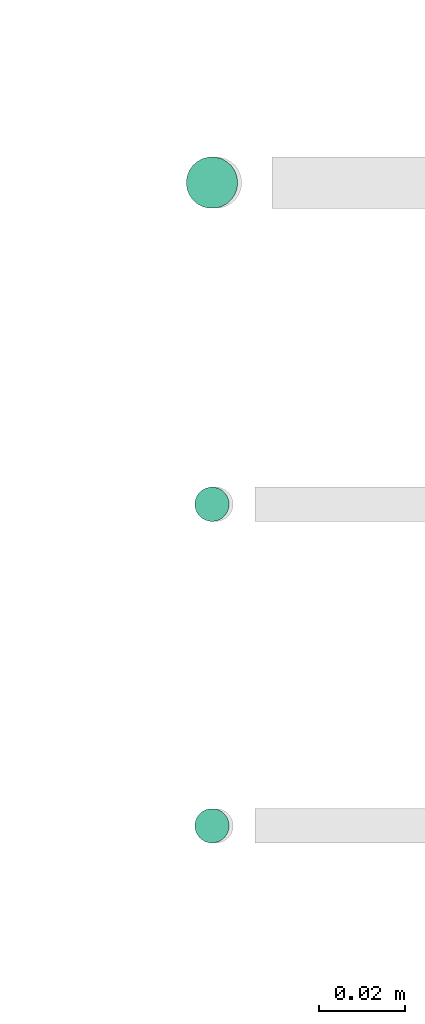
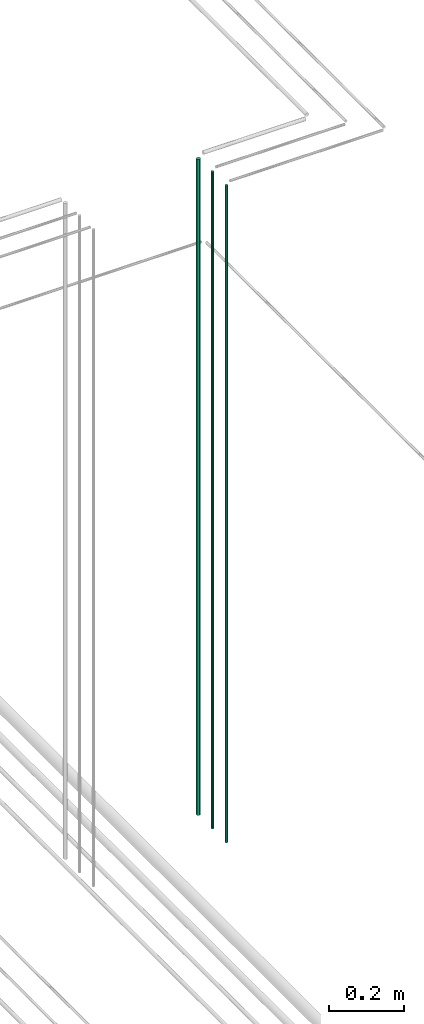
# One storey, part 46 of 331: 3 flow segments.
"""IFC2X3 building model written with IfcOpenShell, lengths in millimetres."""

import ifcopenshell
import ifcopenshell.guid

model = None  # the IFC model being written
_history = None  # IfcOwnerHistory: only IFC2X3 demands one
_inside = {}  # id of a spatial element -> (the spatial element, [elements in it])
_under = {}  # id of a project, library or spatial element -> (it, [spatial elements below it])
_declared = {}  # id of a project -> (the project, [libraries it declares])
_typed = {}  # id of a type object -> (the type object, [elements of that type])
_made_of = {}  # id of a material, layer set ... -> (it, [elements and type objects made of it])


def new_model(schema):
    """Start an empty IFC model of exactly this schema.

    Asked for "IFC4X3", IfcOpenShell would pick the latest addendum, in which some entities
    have other attributes; the version numbers below select the first issue.
    IFC2X3 requires an IfcOwnerHistory on every rooted entity: one is made here for all.
    """
    global model, _history
    if schema == "IFC4X3":
        model = ifcopenshell.file(schema_version=(4, 3, 0, 0))
    else:
        model = ifcopenshell.file(schema=schema)
    _inside.clear()
    _under.clear()
    _declared.clear()
    _typed.clear()
    _made_of.clear()
    _history = None
    if model.schema == "IFC2X3":
        org = make("IfcOrganization", Name="unknown")
        user = make(
            "IfcPersonAndOrganization",
            ThePerson=make("IfcPerson", FamilyName="unknown"),
            TheOrganization=org,
        )
        app = make(
            "IfcApplication",
            ApplicationDeveloper=org,
            Version="unknown",
            ApplicationFullName="unknown",
            ApplicationIdentifier="unknown",
        )
        _history = make(
            "IfcOwnerHistory",
            OwningUser=user,
            OwningApplication=app,
            ChangeAction="ADDED",
            CreationDate=0,
        )
    return model


def make(cls, **values):
    """One entity of the class cls with the attributes given. An attribute that is None is left unset."""
    return model.create_entity(
        cls, **{name: value for name, value in values.items() if value is not None}
    )


def entity(cls, *values):
    """Any entity or typed value of the class cls, its attributes in the order of the schema. None: left unset."""
    e = model.create_entity(cls)
    for i, value in enumerate(values):
        if value is not None:
            e[i] = value
    return e


def rooted(cls, **values):
    """An entity with a GlobalId (a new one), such as an element, a storey or a relation."""
    return make(cls, GlobalId=ifcopenshell.guid.new(), OwnerHistory=_history, **values)


def si_unit(unit_type, name, prefix=None):
    """IfcSIUnit, for example si_unit("LENGTHUNIT", "METRE", prefix="MILLI")."""
    return make("IfcSIUnit", UnitType=unit_type, Prefix=prefix, Name=name)


def converted_unit(unit_type, name, factor, base, dimensions=None, offset=None):
    """IfcConversionBasedUnit, such as the inch: factor (a typed value) times the base unit."""
    return make(
        "IfcConversionBasedUnit"
        if offset is None
        else "IfcConversionBasedUnitWithOffset",
        ConversionOffset=offset,
        Dimensions=None
        if dimensions is None
        else entity("IfcDimensionalExponents", *dimensions),
        UnitType=unit_type,
        Name=name,
        ConversionFactor=make(
            "IfcMeasureWithUnit", ValueComponent=factor, UnitComponent=base
        ),
    )


def derived_unit(unit_type, elements):
    """IfcDerivedUnit: a product of units, each with its exponent."""
    return make(
        "IfcDerivedUnit",
        Elements=[
            make("IfcDerivedUnitElement", Unit=unit, Exponent=power)
            for unit, power in elements
        ],
        UnitType=unit_type,
    )


def assignment(units):
    """IfcUnitAssignment: the units of a project."""
    return None if units is None else make("IfcUnitAssignment", Units=units)


def point(xyz):
    """IfcCartesianPoint."""
    return None if xyz is None else make("IfcCartesianPoint", Coordinates=xyz)


def direction(xyz):
    """IfcDirection."""
    return None if xyz is None else make("IfcDirection", DirectionRatios=xyz)


def frame(location, z_axis=None, x_axis=None):
    """IfcAxis2Placement3D, a coordinate frame: its origin and axes. An axis left out is left unset."""
    return make(
        "IfcAxis2Placement3D",
        Location=point(location),
        Axis=direction(z_axis),
        RefDirection=direction(x_axis),
    )


def frame_2d(location, x_axis=None):
    """IfcAxis2Placement2D, a coordinate frame in the plane: its origin and x axis."""
    return make(
        "IfcAxis2Placement2D", Location=point(location), RefDirection=direction(x_axis)
    )


def origin():
    """The frame at (0, 0, 0) with its axes left unset."""
    return frame((0.0, 0.0, 0.0))


def origin_2d_with_axis():
    """The frame at (0, 0) in the plane with the x axis (1, 0) written out."""
    return frame_2d((0.0, 0.0), x_axis=(1.0, 0.0))


def place(relative_to, where):
    """IfcLocalPlacement: puts the frame where relative to a parent placement (None: the world)."""
    return make(
        "IfcLocalPlacement", PlacementRelTo=relative_to, RelativePlacement=where
    )


def context(
    kind, dimensions, precision=None, world=None, true_north=None, identifier=None
):
    """IfcGeometricRepresentationContext, for example the 3D "Model" context."""
    return make(
        "IfcGeometricRepresentationContext",
        ContextIdentifier=identifier,
        ContextType=kind,
        CoordinateSpaceDimension=dimensions,
        Precision=precision,
        WorldCoordinateSystem=world,
        TrueNorth=true_north,
    )


def subcontext(parent, identifier, kind, view, scale=None):
    """IfcGeometricRepresentationSubContext, for example "Body" below "Model"."""
    return make(
        "IfcGeometricRepresentationSubContext",
        ContextIdentifier=identifier,
        ContextType=kind,
        ParentContext=parent,
        TargetScale=scale,
        TargetView=view,
    )


def project(units=None, contexts=None):
    """IfcProject with its units and contexts."""
    return rooted(
        "IfcProject",
        Name="project",
        RepresentationContexts=contexts,
        UnitsInContext=assignment(units),
    )


def spatial(cls, under=None, at=None, **own):
    """A site, building, storey or space (cls), placed at a placement, below another one or the project."""
    s = rooted(cls, ObjectPlacement=at, **own)
    if under is not None:
        _under.setdefault(under.id(), (under, []))[1].append(s)
    return s


def profile(cls, at=None, kind="AREA", **sizes):
    """A parametric profile (cls). Its sizes go by their IFC names, for example OverallWidth=200.0."""
    return make(cls, ProfileType=kind, Position=at, **sizes)


def circle(**sizes):
    """IfcCircleProfileDef."""
    return profile("IfcCircleProfileDef", **sizes)


def extrude(swept, where, along, depth):
    """IfcExtrudedAreaSolid: the profile swept, set in the frame where, extruded along a direction by depth."""
    return make(
        "IfcExtrudedAreaSolid",
        SweptArea=swept,
        Position=where,
        ExtrudedDirection=direction(along),
        Depth=depth,
    )


def shape(context_of_items, identifier, shape_type, items):
    """IfcShapeRepresentation: the items that make up one representation, for example the "Body"."""
    return make(
        "IfcShapeRepresentation",
        ContextOfItems=context_of_items,
        RepresentationIdentifier=identifier,
        RepresentationType=shape_type,
        Items=items,
    )


def made_of(thing, what):
    """Note that an element or type object is made of a material, layer set ...; save() writes the relation."""
    if what is not None:
        _made_of.setdefault(what.id(), (what, []))[1].append(thing)
    return thing


def type_object(cls, material=None, **own):
    """A type object (cls), such as IfcWallType, which elements share."""
    return made_of(rooted(cls, **own), material)


def element(
    cls,
    number,
    at=None,
    inside=None,
    cuts=None,
    type_object=None,
    material=None,
    context=None,
    identifier="Body",
    shape_type=None,
    held_by="IfcProductDefinitionShape",
    body=None,
    shapes=None,
    **own,
):
    """One element of the class cls, such as IfcWall. Its Tag is "e" and its number.

    at: its placement. inside: the storey or other place that contains it. cuts: it is an
    opening in that element (IfcRelVoidsElement). A single representation is given by context,
    identifier, shape_type and body (its items); several are given by shapes. held_by: the class
    of the entity that holds the representations. save() writes the other relations.
    """
    e = rooted(cls, Tag="e%d" % number, ObjectPlacement=at, **own)
    if body is not None:
        shapes = [shape(context, identifier, shape_type, body)]
    if shapes is not None:
        e.Representation = make(held_by, Representations=shapes)
    if inside is not None:
        _inside.setdefault(inside.id(), (inside, []))[1].append(e)
    if cuts is not None:
        rooted(
            "IfcRelVoidsElement", RelatingBuildingElement=cuts, RelatedOpeningElement=e
        )
    if type_object is not None:
        _typed.setdefault(type_object.id(), (type_object, []))[1].append(e)
    return made_of(e, material)


def aggregate(whole, parts):
    """IfcRelAggregates: a whole, such as a stair, and the parts it consists of."""
    return rooted("IfcRelAggregates", RelatingObject=whole, RelatedObjects=parts)


def save(model, path):
    """Write the relations noted so far, then the file.

    IfcRelAggregates (storeys below a building ...), IfcRelContainedInSpatialStructure (elements
    in a storey), IfcRelDefinesByType, IfcRelAssociatesMaterial and IfcRelDeclares: one each for
    every whole, place, type object, material and project.
    """
    for whole, parts in _under.values():
        aggregate(whole, parts)
    for where, things in _inside.values():
        rooted(
            "IfcRelContainedInSpatialStructure",
            RelatedElements=things,
            RelatingStructure=where,
        )
    for kind, things in _typed.values():
        rooted("IfcRelDefinesByType", RelatedObjects=things, RelatingType=kind)
    for what, things in _made_of.values():
        rooted("IfcRelAssociatesMaterial", RelatedObjects=things, RelatingMaterial=what)
    for by, libraries in _declared.values():
        rooted("IfcRelDeclares", RelatingContext=by, RelatedDefinitions=libraries)
    model.write(path)


model = new_model("IFC2X3")

# Units and contexts
model_context = context("Model", 3, precision=0.01, world=origin(), true_north=direction((6.12303176911189e-17, 1.0)))
body_context = subcontext(model_context, "Body", "Model", "MODEL_VIEW")
ifc_project = project(units=[si_unit("LENGTHUNIT", "METRE", prefix="MILLI"), si_unit("AREAUNIT", "SQUARE_METRE"), si_unit("VOLUMEUNIT", "CUBIC_METRE"), converted_unit("PLANEANGLEUNIT", "DEGREE", entity("IfcRatioMeasure", 0.0174532925199433), si_unit("PLANEANGLEUNIT", "RADIAN"), dimensions=[0, 0, 0, 0, 0, 0, 0]), si_unit("MASSUNIT", "GRAM", prefix="KILO"), derived_unit("MASSDENSITYUNIT", [(si_unit("MASSUNIT", "GRAM", prefix="KILO"), 1), (si_unit("LENGTHUNIT", "METRE"), -3)]), derived_unit("MOMENTOFINERTIAUNIT", [(si_unit("LENGTHUNIT", "METRE"), 4)]), si_unit("TIMEUNIT", "SECOND"), si_unit("FREQUENCYUNIT", "HERTZ"), si_unit("THERMODYNAMICTEMPERATUREUNIT", "DEGREE_CELSIUS"), derived_unit("THERMALTRANSMITTANCEUNIT", [(si_unit("MASSUNIT", "GRAM", prefix="KILO"), 1), (si_unit("THERMODYNAMICTEMPERATUREUNIT", "KELVIN"), -1), (si_unit("TIMEUNIT", "SECOND"), -3)]), derived_unit("VOLUMETRICFLOWRATEUNIT", [(si_unit("LENGTHUNIT", "METRE"), 3), (si_unit("TIMEUNIT", "SECOND"), -1)]), derived_unit("MASSFLOWRATEUNIT", [(si_unit("MASSUNIT", "GRAM", prefix="KILO"), 1), (si_unit("TIMEUNIT", "SECOND"), -1)]), derived_unit("ROTATIONALFREQUENCYUNIT", [(si_unit("TIMEUNIT", "SECOND"), -1)]), si_unit("ELECTRICCURRENTUNIT", "AMPERE"), si_unit("ELECTRICVOLTAGEUNIT", "VOLT"), si_unit("POWERUNIT", "WATT"), si_unit("FORCEUNIT", "NEWTON", prefix="KILO"), si_unit("ILLUMINANCEUNIT", "LUX"), si_unit("LUMINOUSFLUXUNIT", "LUMEN"), si_unit("LUMINOUSINTENSITYUNIT", "CANDELA"), derived_unit("USERDEFINED", [(si_unit("MASSUNIT", "GRAM", prefix="KILO"), -1), (si_unit("LENGTHUNIT", "METRE"), -2), (si_unit("TIMEUNIT", "SECOND"), 3), (si_unit("LUMINOUSFLUXUNIT", "LUMEN"), 1)]), derived_unit("LINEARVELOCITYUNIT", [(si_unit("LENGTHUNIT", "METRE"), 1), (si_unit("TIMEUNIT", "SECOND"), -1)]), si_unit("PRESSUREUNIT", "PASCAL"), derived_unit("USERDEFINED", [(si_unit("LENGTHUNIT", "METRE"), -2), (si_unit("MASSUNIT", "GRAM", prefix="KILO"), 1), (si_unit("TIMEUNIT", "SECOND"), -2)]), derived_unit("LINEARFORCEUNIT", [(si_unit("MASSUNIT", "GRAM", prefix="KILO"), 1), (si_unit("LENGTHUNIT", "METRE"), 1), (si_unit("TIMEUNIT", "SECOND"), -2), (si_unit("LENGTHUNIT", "METRE"), -1)]), derived_unit("PLANARFORCEUNIT", [(si_unit("MASSUNIT", "GRAM", prefix="KILO"), 1), (si_unit("LENGTHUNIT", "METRE"), 1), (si_unit("TIMEUNIT", "SECOND"), -2), (si_unit("LENGTHUNIT", "METRE"), -2)])], contexts=[model_context])

# Site, building, storey
site_placement = place(None, frame((0.0, -0.00077364408347762, 0.0)))
site = spatial("IfcSite", under=ifc_project, at=site_placement, CompositionType="ELEMENT")
building_placement = place(site_placement, origin())
building = spatial("IfcBuilding", under=site, at=building_placement, CompositionType="ELEMENT")
storey_placement = place(building_placement, origin())
storey = spatial("IfcBuildingStorey", under=building, at=storey_placement, CompositionType="ELEMENT", Elevation=0.0)

# Flow segments
pipe_segment_type = type_object("IfcPipeSegmentType", PredefinedType="NOTDEFINED")
flow_segment_1_placement = place(storey_placement, frame((53568.1864417171, 1343.89349484376, 16890.0)))
element("IfcFlowSegment", 1, at=flow_segment_1_placement, inside=storey, type_object=pipe_segment_type, context=body_context, shape_type="SweptSolid", body=[
    extrude(circle(Radius=6.0, at=origin_2d_with_axis()), frame((7.59527223591454, 7.59527223591589, 0.0)), (0.0, 0.0, 1.0), 2146.0),
])
flow_segment_2_placement = place(storey_placement, frame((53570.1864417171, 1270.89349484376, 16890.0)))
element("IfcFlowSegment", 2, at=flow_segment_2_placement, inside=storey, type_object=pipe_segment_type, context=body_context, shape_type="SweptSolid", body=[
    extrude(circle(Radius=4.0, at=origin_2d_with_axis()), frame((5.59527223591499, 5.5952722359158, 0.0)), (0.0, 0.0, 1.0), 2150.00000000001),
])
flow_segment_3_placement = place(storey_placement, frame((53570.1864417171, 1195.89349484376, 16890.0)))
element("IfcFlowSegment", 3, at=flow_segment_3_placement, inside=storey, type_object=pipe_segment_type, context=body_context, shape_type="SweptSolid", body=[
    extrude(circle(Radius=4.0, at=origin_2d_with_axis()), frame((5.59527223591499, 5.59527223591607, 0.0)), (0.0, 0.0, 1.0), 2150.00000000001),
])

save(model, "model.ifc")
